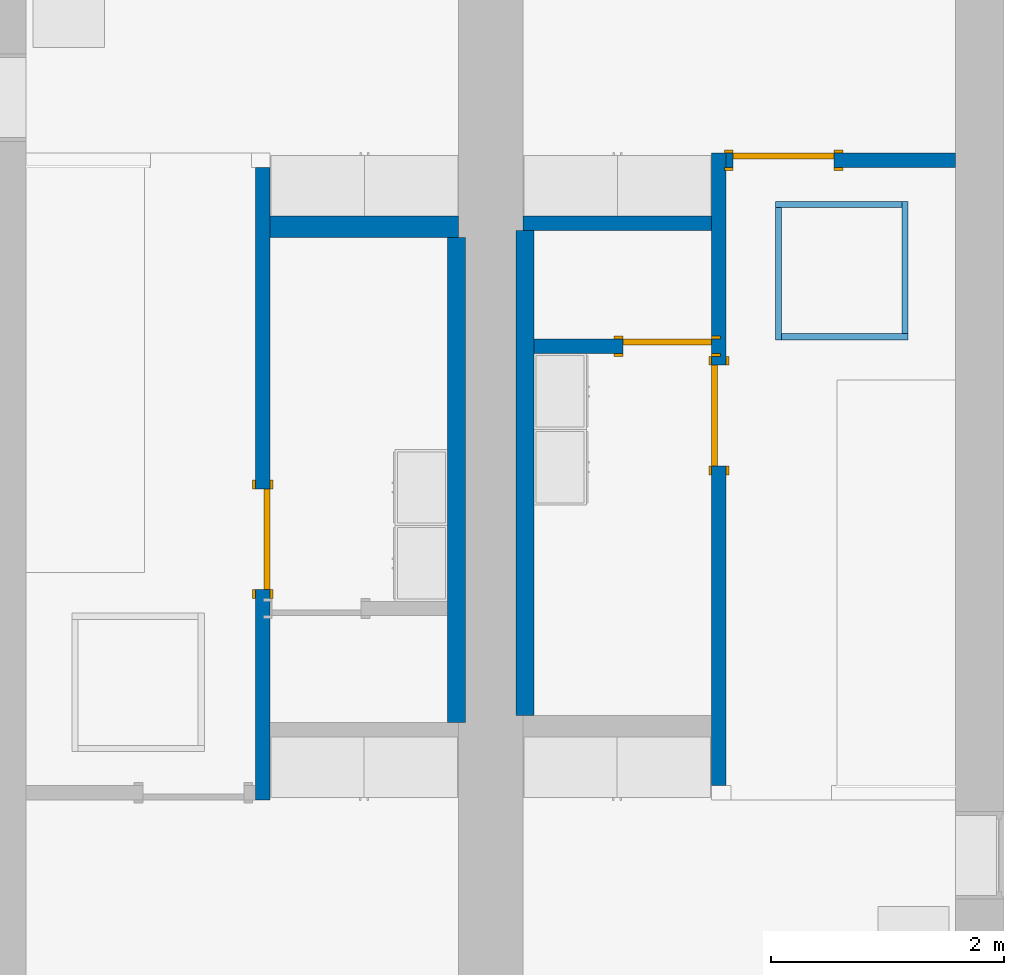
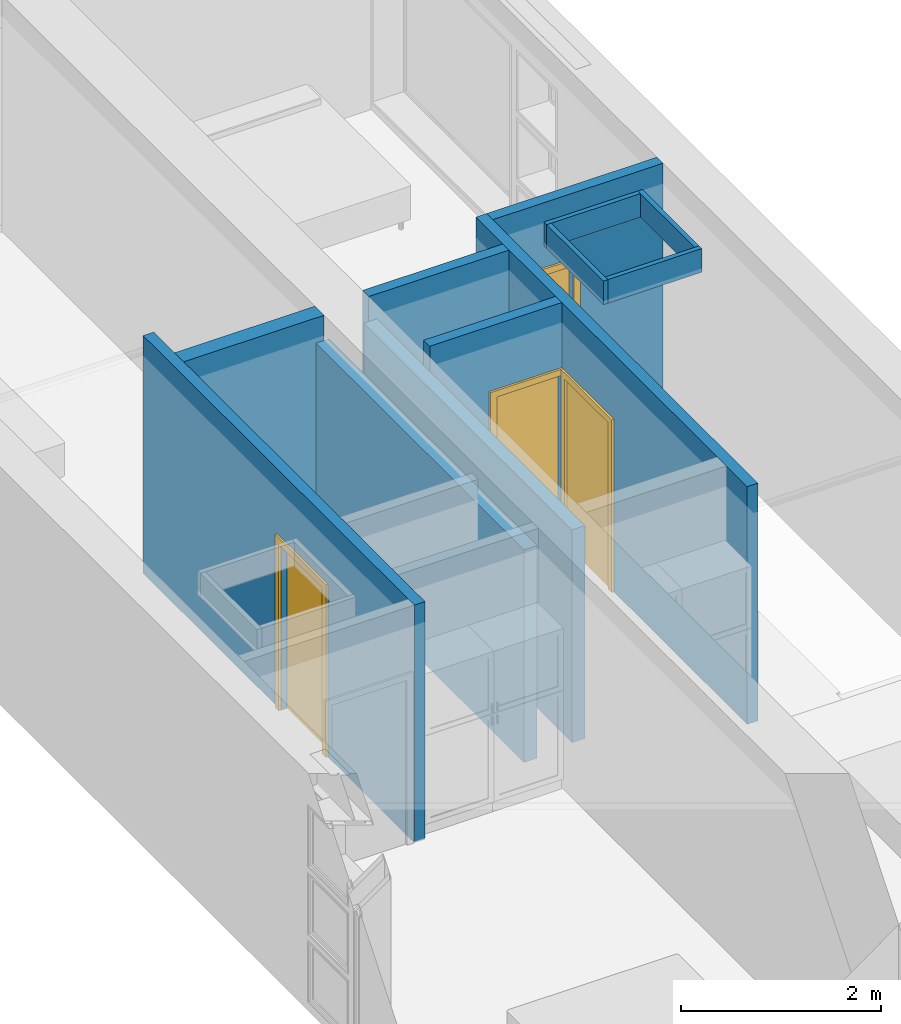
# One storey, part 3 of 14: 12 walls, 4 doors, 4 openings.
"""IFC2X3 building model written with IfcOpenShell, lengths in metres."""

from ifc_helpers import new_model, entity, si_unit, converted_unit, frame, frame_2d, origin, origin_2d_with_axis, place, context, project, spatial, polyline, rectangle, outline, extrude, source, transform, mapped, material, layer, layer_set, layer_usage, type_object, type_shapes, element, fill, save


model = new_model("IFC2X3")

# Units and contexts
model_context = context("Model", 3, precision=1e-09, world=origin())
plan_context = context("Plan", 3, precision=1e-09, world=origin())
ifc_project = project(units=[si_unit("LENGTHUNIT", "METRE"), si_unit("AREAUNIT", "SQUARE_METRE"), si_unit("VOLUMEUNIT", "CUBIC_METRE"), converted_unit("PLANEANGLEUNIT", "DEGREE", entity("IfcRatioMeasure", 0.01745329251994328), si_unit("PLANEANGLEUNIT", "RADIAN"), dimensions=[0, 0, 0, 0, 0, 0, 0]), si_unit("TIMEUNIT", "SECOND")], contexts=[model_context, plan_context])

# Site, building, storey
site_placement = place(None, origin())
site = spatial("IfcSite", under=ifc_project, at=site_placement, CompositionType="ELEMENT")
building_placement = place(site_placement, origin())
building = spatial("IfcBuilding", under=site, at=building_placement, CompositionType="ELEMENT")
storey_placement = place(building_placement, frame((0.0, 0.0, 3.100000000000378)))
storey = spatial("IfcBuildingStorey", under=building, at=storey_placement, Name="Level 2", CompositionType="ELEMENT", Elevation=3.100000000000378)

# Wall, opening, door
ifc_material_1 = material(Name="Plasterboard")
ifc_layer_1 = layer(ifc_material_1, 0.016)
ifc_material_2 = material(Name="Metal - Stud Layer")
ifc_layer_2 = layer(ifc_material_2, 0.092)
ifc_layer_3 = layer(ifc_material_1, 0.016)
ifc_layer_set_1 = layer_set([ifc_layer_1, ifc_layer_2, ifc_layer_3], Name="Basic Wall:Interior - Partition (92mm Stud)")
ifc_layer_usage_1 = layer_usage(ifc_layer_set_1, "AXIS2", "NEGATIVE", 0.062)
wall_1_placement = place(storey_placement, frame((6.356, -11.55, 0.0), z_axis=(0.0, 0.0, 1.0), x_axis=(0.0, 1.0, 0.0)))
wall_1 = element("IfcWallStandardCase", 1, at=wall_1_placement, inside=storey, material=ifc_layer_usage_1, Name="Basic Wall:Interior - Partition (92mm Stud)", ObjectType="Basic Wall:Interior - Partition (92mm Stud)", context=model_context, shape_type="SweptSolid", body=[
    extrude(rectangle(XDim=5.423999999999995, YDim=0.124, at=frame_2d((2.711999999999998, 0.0), x_axis=(-1.0, 0.0))), origin(), (0.0, 0.0, 1.0), 2.900000000000012),
])
opening_1_placement = place(wall_1_placement, frame((2.74061576492847, -0.0620000000000056, 0.0)))
opening_1 = element("IfcOpeningElement", 2, at=opening_1_placement, cuts=wall_1, Name="M_Single-Flush:0864 x 2032mm:0864 x 2032mm:1", ObjectType="Opening", context=model_context, shape_type="SweptSolid", body=[
    extrude(rectangle(XDim=0.8639999999999994, YDim=2.032, at=frame_2d((1.016, 0.4319999999999998), x_axis=(0.0, 1.0))), frame((0.0, 0.0, 0.0), z_axis=(0.0, 1.0, 0.0), x_axis=(0.0, 0.0, 1.0)), (0.0, 0.0, 1.0), 0.124),
])
door_style_1 = type_object("IfcDoorStyle", Name="0864 x 2032mm", ConstructionType="NOTDEFINED", OperationType="SINGLE_SWING_RIGHT", ParameterTakesPrecedence=False, Sizeable=False)
shared_shape_1 = source(origin(), model_context, "Body", "SweptSolid", [
    extrude(outline(polyline([(-0.5079999999999999, -1.072999999999999), (0.5079999999999998, -1.072999999999999), (0.5079999999999998, 1.035000000000001), (0.4319999999999997, 1.035000000000001), (0.4319999999999997, -0.9970000000000019), (-0.4319999999999996, -0.9970000000000019), (-0.4319999999999996, 1.035000000000001), (-0.5079999999999999, 1.035000000000001), (-0.5079999999999999, -1.072999999999999)])), frame((0.4320000000000008, 0.1239999999999992, 1.035000000000001), z_axis=(0.0, 1.0, 0.0), x_axis=(1.0, 0.0, 0.0)), (0.0, 0.0, 1.0), 0.02499999999999444),
    extrude(outline(polyline([(-1.073, -0.5079999999999971), (1.035, -0.5079999999999971), (1.035, -0.4320000000000073), (-0.9969999999999997, -0.4320000000000073), (-0.9969999999999997, 0.4320000000000018), (1.035, 0.4320000000000018), (1.035, 0.5080000000000027), (-1.073, 0.5080000000000027), (-1.073, -0.5079999999999971)])), frame((0.4320000000000031, -0.02500000000000638, 1.035), z_axis=(0.0, 1.0, 0.0), x_axis=(0.0, 0.0, -1.0)), (0.0, 0.0, 1.0), 0.02500000000000558),
    extrude(rectangle(XDim=0.051, YDim=0.8639999999999998, at=origin_2d_with_axis()), frame((0.4320000000000005, 0.0984999999999992, 0.0), z_axis=(0.0, 0.0, 1.0), x_axis=(0.0, 1.0, 0.0)), (0.0, 0.0, 1.0), 2.032),
])
type_shapes(door_style_1, [shared_shape_1])
door_1_placement = place(opening_1_placement, origin())
door_1 = element("IfcDoor", 3, at=door_1_placement, inside=storey, type_object=door_style_1, Name="M_Single-Flush:0864 x 2032mm:0864 x 2032mm", ObjectType="0864 x 2032mm", OverallHeight=2.032, OverallWidth=0.8639999999999995, context=model_context, shape_type="MappedRepresentation", body=[
    mapped(shared_shape_1, transform((0.0, 0.0, 0.0), scale=1.0)),
])
fill(opening_1, door_1)

wall_2_placement = place(storey_placement, frame((2.444, -6.250000000000009, 0.0), z_axis=(0.0, 0.0, 1.0), x_axis=(0.0, -1.0, 0.0)))
wall_2 = element("IfcWallStandardCase", 4, at=wall_2_placement, inside=storey, material=ifc_layer_usage_1, Name="Basic Wall:Interior - Partition (92mm Stud)", ObjectType="Basic Wall:Interior - Partition (92mm Stud)", context=model_context, shape_type="SweptSolid", body=[
    extrude(rectangle(XDim=5.423999999999995, YDim=0.1240000000000002, at=frame_2d((2.711999999999998, 0.0), x_axis=(-1.0, 0.0))), origin(), (0.0, 0.0, 1.0), 2.900000000000012),
])
opening_2_placement = place(wall_2_placement, frame((2.75605117851058, -0.06200000000000567, 0.0)))
opening_2 = element("IfcOpeningElement", 5, at=opening_2_placement, cuts=wall_2, Name="M_Single-Flush:0864 x 2032mm:0864 x 2032mm:1", ObjectType="Opening", context=model_context, shape_type="SweptSolid", body=[
    extrude(rectangle(XDim=0.8639999999999994, YDim=2.032, at=frame_2d((1.016, 0.4319999999999993), x_axis=(0.0, 1.0))), frame((0.0, 0.0, 0.0), z_axis=(0.0, 1.0, 0.0), x_axis=(0.0, 0.0, 1.0)), (0.0, 0.0, 1.0), 0.124),
])
door_2_placement = place(opening_2_placement, origin())
door_2 = element("IfcDoor", 6, at=door_2_placement, inside=storey, type_object=door_style_1, Name="M_Single-Flush:0864 x 2032mm:0864 x 2032mm", ObjectType="0864 x 2032mm", OverallHeight=2.032, OverallWidth=0.8639999999999985, context=model_context, shape_type="MappedRepresentation", body=[
    mapped(shared_shape_1, transform((0.0, 0.0, 0.0), scale=1.0)),
])
fill(opening_2, door_2)

# Walls
ifc_layer_4 = layer(ifc_material_1, 0.016)
ifc_layer_5 = layer(ifc_material_2, 0.152)
ifc_layer_6 = layer(ifc_material_1, 0.016)
ifc_layer_set_2 = layer_set([ifc_layer_4, ifc_layer_5, ifc_layer_6], Name="Basic Wall:Interior - Plumbing (152mm Stud)")
ifc_layer_usage_2 = layer_usage(ifc_layer_set_2, "AXIS2", "NEGATIVE", 0.092)
wall_3_placement = place(storey_placement, frame((2.505999999999999, -6.758000000000003, 0.0)))
element("IfcWallStandardCase", 7, at=wall_3_placement, inside=storey, material=ifc_layer_usage_2, Name="Basic Wall:Interior - Plumbing (152mm Stud)", ObjectType="Basic Wall:Interior - Plumbing (152mm Stud)", context=model_context, shape_type="SweptSolid", body=[
    extrude(rectangle(XDim=1.618999999999992, YDim=0.1839999999999993, at=frame_2d((0.8094999999999958, 0.0), x_axis=(-1.0, 0.0))), origin(), (0.0, 0.0, 1.0), 2.900000000000012),
])
wall_4_placement = place(storey_placement, frame((4.674999999999989, -6.728000000000002, 0.0)))
element("IfcWallStandardCase", 8, at=wall_4_placement, inside=storey, material=ifc_layer_usage_1, Name="Basic Wall:Interior - Partition (92mm Stud)", ObjectType="Basic Wall:Interior - Partition (92mm Stud)", context=model_context, shape_type="SweptSolid", body=[
    extrude(rectangle(XDim=1.619000000000017, YDim=0.124, at=frame_2d((0.809500000000009, 0.0), x_axis=(-1.0, 0.0))), origin(), (0.0, 0.0, 1.0), 2.900000000000012),
])

# Wall, opening, door
ifc_layer_usage_3 = layer_usage(ifc_layer_set_1, "AXIS2", "POSITIVE", -0.062)
wall_5_placement = place(storey_placement, frame((4.769999999999988, -7.783384235071523, 0.0)))
wall_5 = element("IfcWallStandardCase", 9, at=wall_5_placement, inside=storey, material=ifc_layer_usage_3, Name="Basic Wall:Interior - Partition (92mm Stud)", ObjectType="Basic Wall:Interior - Partition (92mm Stud)", context=model_context, shape_type="SweptSolid", body=[
    extrude(rectangle(XDim=1.524000000000019, YDim=0.124, at=frame_2d((0.7620000000000092, 0.0), x_axis=(-1.0, 0.0))), origin(), (0.0, 0.0, 1.0), 2.900000000000012),
])
opening_3_placement = place(wall_5_placement, frame((0.7613750000000165, -0.06200000000000323, 0.0)))
opening_3 = element("IfcOpeningElement", 10, at=opening_3_placement, cuts=wall_5, Name="M_Single-Flush:0762 x 2032mm:0762 x 2032mm:1", ObjectType="Opening", context=model_context, shape_type="SweptSolid", body=[
    extrude(rectangle(XDim=0.7619999999999997, YDim=2.032, at=frame_2d((1.016, 0.3809999999999995), x_axis=(0.0, 1.0))), frame((0.0, 0.0, 0.0), z_axis=(0.0, 1.0, 0.0), x_axis=(0.0, 0.0, 1.0)), (0.0, 0.0, 1.0), 0.124),
])
door_style_2 = type_object("IfcDoorStyle", Name="0762 x 2032mm", ConstructionType="NOTDEFINED", OperationType="SINGLE_SWING_RIGHT", ParameterTakesPrecedence=False, Sizeable=False)
shared_shape_2 = source(origin(), model_context, "Body", "SweptSolid", [
    extrude(outline(polyline([(-0.457, -1.072999999999999), (0.4569999999999999, -1.072999999999999), (0.4569999999999999, 1.035000000000001), (0.3809999999999998, 1.035000000000001), (0.3809999999999998, -0.9970000000000019), (-0.3809999999999997, -0.9970000000000019), (-0.3809999999999997, 1.035000000000001), (-0.457, 1.035000000000001), (-0.457, -1.072999999999999)])), frame((0.3810000000000009, 0.1239999999999993, 1.035000000000001), z_axis=(0.0, 1.0, 0.0), x_axis=(1.0, 0.0, 0.0)), (0.0, 0.0, 1.0), 0.02499999999999445),
    extrude(outline(polyline([(-1.073, -0.4569999999999971), (1.035, -0.4569999999999971), (1.035, -0.3810000000000074), (-0.9969999999999997, -0.3810000000000074), (-0.9969999999999997, 0.3810000000000018), (1.035, 0.3810000000000018), (1.035, 0.4570000000000027), (-1.073, 0.4570000000000027), (-1.073, -0.4569999999999971)])), frame((0.3810000000000031, -0.02500000000000627, 1.035), z_axis=(0.0, 1.0, 0.0), x_axis=(0.0, 0.0, -1.0)), (0.0, 0.0, 1.0), 0.02500000000000558),
    extrude(rectangle(XDim=0.051, YDim=0.7619999999999998, at=origin_2d_with_axis()), frame((0.3810000000000005, 0.09849999999999928, 0.0), z_axis=(0.0, 0.0, 1.0), x_axis=(0.0, 1.0, 0.0)), (0.0, 0.0, 1.0), 2.032),
])
type_shapes(door_style_2, [shared_shape_2])
door_3_placement = place(opening_3_placement, origin())
door_3 = element("IfcDoor", 11, at=door_3_placement, inside=storey, type_object=door_style_2, Name="M_Single-Flush:0762 x 2032mm:0762 x 2032mm", ObjectType="0762 x 2032mm", OverallHeight=2.032, OverallWidth=0.762, context=model_context, shape_type="MappedRepresentation", body=[
    mapped(shared_shape_2, transform((0.0, 0.0, 0.0), scale=1.0)),
])
fill(opening_3, door_3)

# Wall
ifc_layer_7 = layer(ifc_material_2, 0.136)
ifc_layer_8 = layer(ifc_material_1, 0.016)
ifc_layer_set_3 = layer_set([ifc_layer_7, ifc_layer_8], Name="Basic Wall:Interior - Furring (152 mm Stud)")
ifc_layer_usage_4 = layer_usage(ifc_layer_set_3, "AXIS2", "POSITIVE", -0.07600000000000001)
wall_6_placement = place(storey_placement, frame((4.105999999999982, -11.01, 0.0), z_axis=(0.0, 0.0, 1.0), x_axis=(0.0, 1.0, 0.0)))
element("IfcWallStandardCase", 12, at=wall_6_placement, inside=storey, material=ifc_layer_usage_4, Name="Basic Wall:Interior - Furring (152 mm Stud)", ObjectType="Basic Wall:Interior - Furring (152 mm Stud)", context=model_context, shape_type="SweptSolid", body=[
    extrude(rectangle(XDim=4.159999999999996, YDim=0.1520000000000001, at=frame_2d((2.079999999999998, 0.0), x_axis=(-1.0, 0.0))), origin(), (0.0, 0.0, 1.0), 2.595000000000012),
])

# Wall, opening, door
wall_7_placement = place(storey_placement, frame((6.418000000000008, -6.188000000000002, 0.0)))
wall_7 = element("IfcWallStandardCase", 13, at=wall_7_placement, inside=storey, material=ifc_layer_usage_1, Name="Basic Wall:Interior - Partition (92mm Stud)", ObjectType="Basic Wall:Interior - Partition (92mm Stud)", context=model_context, shape_type="SweptSolid", body=[
    extrude(rectangle(XDim=1.964999999999982, YDim=0.124, at=frame_2d((0.982499999999991, 0.0), x_axis=(-1.0, 0.0))), origin(), (0.0, 0.0, 1.0), 2.900000000000012),
])
opening_4_placement = place(wall_7_placement, frame((0.06000000000000016, -0.0620000000000021, 0.0)))
opening_4 = element("IfcOpeningElement", 14, at=opening_4_placement, cuts=wall_7, Name="M_Single-Flush:0864 x 2032mm:0864 x 2032mm:1", ObjectType="Opening", context=model_context, shape_type="SweptSolid", body=[
    extrude(rectangle(XDim=0.8639999999999995, YDim=2.032, at=frame_2d((1.016, 0.432), x_axis=(0.0, -1.0))), frame((0.0, 0.0, 0.0), z_axis=(0.0, 1.0, 0.0), x_axis=(0.0, 0.0, 1.0)), (0.0, 0.0, 1.0), 0.124),
])
door_style_3 = type_object("IfcDoorStyle", Name="0864 x 2032mm", ConstructionType="NOTDEFINED", OperationType="SINGLE_SWING_LEFT", ParameterTakesPrecedence=False, Sizeable=False)
shared_shape_3 = source(origin(), model_context, "Body", "SweptSolid", [
    extrude(outline(polyline([(-0.5079999999999999, -1.072999999999999), (0.5079999999999998, -1.072999999999999), (0.5079999999999998, 1.035000000000001), (0.4319999999999997, 1.035000000000001), (0.4319999999999997, -0.9970000000000019), (-0.4319999999999996, -0.9970000000000019), (-0.4319999999999996, 1.035000000000001), (-0.5079999999999999, 1.035000000000001), (-0.5079999999999999, -1.072999999999999)])), frame((0.4320000000000002, 0.1489999999999882, 1.035000000000001), z_axis=(0.0, -1.0, 0.0), x_axis=(-1.0, 0.0, 0.0)), (0.0, 0.0, 1.0), 0.02499999999999444),
    extrude(outline(polyline([(-1.073, -0.5079999999999971), (1.035, -0.5079999999999971), (1.035, -0.4320000000000073), (-0.9969999999999997, -0.4320000000000073), (-0.9969999999999997, 0.4320000000000018), (1.035, 0.4320000000000018), (1.035, 0.5080000000000027), (-1.073, 0.5080000000000027), (-1.073, -0.5079999999999971)])), frame((0.4319999999999979, 0.0, 1.035), z_axis=(0.0, -1.0, 0.0), x_axis=(0.0, 0.0, -1.0)), (0.0, 0.0, 1.0), 0.02500000000000558),
    extrude(rectangle(XDim=0.8639999999999998, YDim=0.051, at=origin_2d_with_axis()), frame((0.4320000000000005, 0.09849999999999375, 0.0)), (0.0, 0.0, 1.0), 2.032),
])
type_shapes(door_style_3, [shared_shape_3])
door_4_placement = place(opening_4_placement, origin())
door_4 = element("IfcDoor", 15, at=door_4_placement, inside=storey, type_object=door_style_3, Name="M_Single-Flush:0864 x 2032mm:0864 x 2032mm", ObjectType="0864 x 2032mm", OverallHeight=2.032, OverallWidth=0.8639999999999995, context=model_context, shape_type="MappedRepresentation", body=[
    mapped(shared_shape_3, transform((0.0, 0.0, 0.0), scale=1.0)),
])
fill(opening_4, door_4)

# Walls
wall_8_placement = place(storey_placement, frame((4.693999999999989, -6.790000000000003, 0.0), z_axis=(0.0, 0.0, 1.0), x_axis=(0.0, -1.0, 0.0)))
element("IfcWallStandardCase", 16, at=wall_8_placement, inside=storey, material=ifc_layer_usage_4, Name="Basic Wall:Interior - Furring (152 mm Stud)", ObjectType="Basic Wall:Interior - Furring (152 mm Stud)", context=model_context, shape_type="SweptSolid", body=[
    extrude(rectangle(XDim=4.160000000000006, YDim=0.1520000000000001, at=frame_2d((2.080000000000003, 0.0), x_axis=(-1.0, 0.0))), origin(), (0.0, 0.0, 1.0), 2.595000000000012),
])
ifc_layer_9 = layer(ifc_material_2, 0.038)
ifc_layer_10 = layer(ifc_material_1, 0.016)
ifc_layer_set_4 = layer_set([ifc_layer_9, ifc_layer_10], Name="Basic Wall:Interior - Furring (38 mm Stud)")
ifc_layer_usage_5 = layer_usage(ifc_layer_set_4, "AXIS2", "NEGATIVE", 0.027)
wall_9_placement = place(storey_placement, frame((6.84045000000003, -6.567450000000052, 2.612)))
element("IfcWallStandardCase", 17, at=wall_9_placement, inside=storey, material=ifc_layer_usage_5, Name="Basic Wall:Interior - Furring (38 mm Stud)", ObjectType="Basic Wall:Interior - Furring (38 mm Stud)", context=model_context, shape_type="SweptSolid", body=[
    extrude(rectangle(XDim=1.083100000000001, YDim=0.05400000000000072, at=frame_2d((0.5415500000000003, 0.0), x_axis=(-1.0, 0.0))), origin(), (0.0, 0.0, 1.0), 0.2880000000000125),
])
wall_10_placement = place(storey_placement, frame((7.977550000000031, -7.702550000000009, 2.612), z_axis=(0.0, 0.0, 1.0), x_axis=(-1.0, 0.0, 0.0)))
element("IfcWallStandardCase", 18, at=wall_10_placement, inside=storey, material=ifc_layer_usage_5, Name="Basic Wall:Interior - Furring (38 mm Stud)", ObjectType="Basic Wall:Interior - Furring (38 mm Stud)", context=model_context, shape_type="SweptSolid", body=[
    extrude(rectangle(XDim=1.083100000000001, YDim=0.05400000000000071, at=frame_2d((0.5415500000000003, 0.0), x_axis=(-1.0, 0.0))), origin(), (0.0, 0.0, 1.0), 0.2880000000000125),
])
wall_11_placement = place(storey_placement, frame((7.95055000000003, -6.540450000000051, 2.612), z_axis=(0.0, 0.0, 1.0), x_axis=(0.0, -1.0, 0.0)))
element("IfcWallStandardCase", 19, at=wall_11_placement, inside=storey, material=ifc_layer_usage_5, Name="Basic Wall:Interior - Furring (38 mm Stud)", ObjectType="Basic Wall:Interior - Furring (38 mm Stud)", context=model_context, shape_type="SweptSolid", body=[
    extrude(rectangle(XDim=1.13509999999996, YDim=0.05400000000000072, at=frame_2d((0.5675499999999798, 0.0), x_axis=(-1.0, 0.0))), origin(), (0.0, 0.0, 1.0), 0.2880000000000125),
])
wall_12_placement = place(storey_placement, frame((6.867450000000031, -7.729550000000008, 2.612), z_axis=(0.0, 0.0, 1.0), x_axis=(0.0, 1.0, 0.0)))
element("IfcWallStandardCase", 20, at=wall_12_placement, inside=storey, material=ifc_layer_usage_5, Name="Basic Wall:Interior - Furring (38 mm Stud)", ObjectType="Basic Wall:Interior - Furring (38 mm Stud)", context=model_context, shape_type="SweptSolid", body=[
    extrude(rectangle(XDim=1.135099999999957, YDim=0.05400000000000072, at=frame_2d((0.5675499999999787, 0.0), x_axis=(-1.0, 0.0))), origin(), (0.0, 0.0, 1.0), 0.2880000000000125),
])

save(model, "model.ifc")
